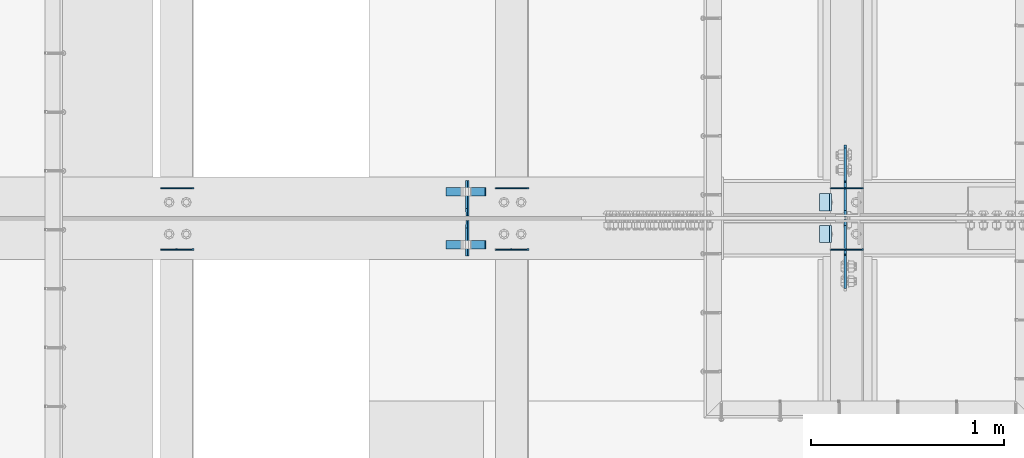
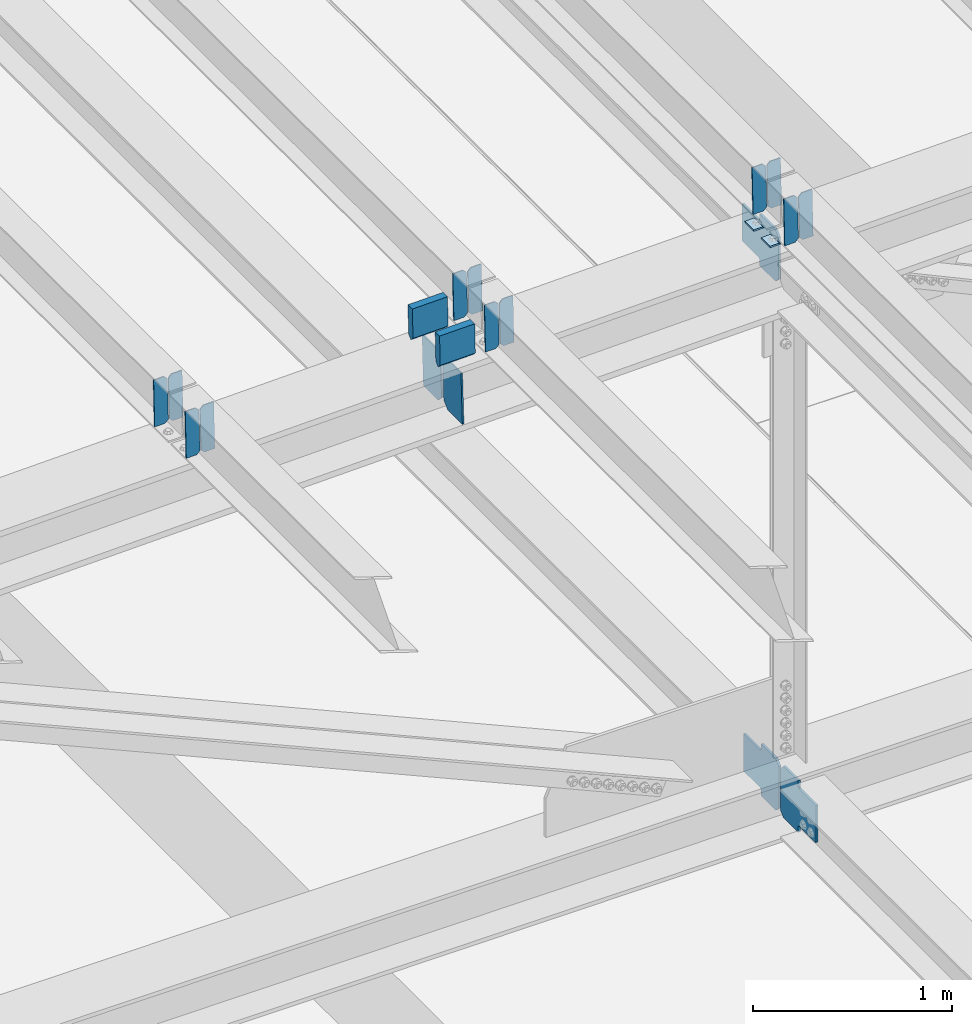
# One storey, part 3434 of 3843: 21 plates, 8 elements without a shape of their own.
"""IFC2X3 building model written with IfcOpenShell, lengths in millimetres."""

from ifc_helpers import new_model, si_unit, frame, origin_with_axes, place, context, subcontext, project, spatial, faceted_brep, material, type_object, element, aggregate, save


model = new_model("IFC2X3")

# Units and contexts
model_context = context("Model", 3, precision=1e-05, world=origin_with_axes())
body_context = subcontext(model_context, "Body", "Model", "MODEL_VIEW")
ifc_project = project(units=[si_unit("LENGTHUNIT", "METRE", prefix="MILLI"), si_unit("AREAUNIT", "SQUARE_METRE"), si_unit("VOLUMEUNIT", "CUBIC_METRE"), si_unit("MASSUNIT", "GRAM", prefix="KILO"), si_unit("TIMEUNIT", "SECOND"), si_unit("PLANEANGLEUNIT", "RADIAN"), si_unit("SOLIDANGLEUNIT", "STERADIAN"), si_unit("THERMODYNAMICTEMPERATUREUNIT", "DEGREE_CELSIUS"), si_unit("LUMINOUSINTENSITYUNIT", "LUMEN")], contexts=[model_context])

# Site, building, storey
site_placement = place(None, origin_with_axes())
site = spatial("IfcSite", under=ifc_project, at=site_placement, CompositionType="ELEMENT")
building_placement = place(site_placement, origin_with_axes())
building = spatial("IfcBuilding", under=site, at=building_placement, Name="Undefined", CompositionType="ELEMENT")
storey_placement = place(building_placement, origin_with_axes())
storey = spatial("IfcBuildingStorey", under=building, at=storey_placement, Name="Undefined", CompositionType="ELEMENT", Elevation=0.0)

# Assembly, plates
assembly_1_placement = place(storey_placement, origin_with_axes())
assembly_1 = element("IfcElementAssembly", 1, at=assembly_1_placement, inside=storey, Name="BEAM", AssemblyPlace="NOTDEFINED", PredefinedType="RIGID_FRAME")
ifc_material = material(Name="STEEL/A572-50")
plate_type_1 = type_object("IfcPlateType", PredefinedType="NOTDEFINED")
plate_1_placement = place(assembly_1_placement, frame((49078.8964783454, 67427.1449316695, 45754.9808067172), z_axis=(-0.0211520979474298, 0.0011058869996923, 0.999775657718454), x_axis=(-0.999776269348562, -2.42820000429985e-05, -0.0211520840073776)))
plate_1 = element("IfcPlate", 2, at=plate_1_placement, type_object=plate_type_1, material=ifc_material, Name="PLATE", context=body_context, shape_type="Brep", body=[
    faceted_brep([(0.0, -3.17499999999927, 0.0), (6.83940015733242e-10, -3.17499999996653, 288.924999998613), (6.54836185276508e-10, 3.17500000001746, 288.924999998591), (0.0, 3.17499999999927, 0.0), (60.3250007643655, -3.17500000017753, 288.924999998606), (60.3250007643219, 3.17499999979918, 288.924999998584), (79.3750000013097, -3.17500000025029, 269.875000761494), (79.375000001266, 3.17499999972642, 269.875000761487), (79.375000000713, -3.17500000026484, 19.0499992370605), (79.3750000006985, 3.17499999971187, 19.0499992370533), (60.325000763667, -3.17500000020664, -1.45519152283669e-11), (60.3250007636234, 3.17499999977736, -3.63797880709171e-11)], [[[0, 1, 2, 3]], [[1, 4, 5, 2]], [[4, 6, 7, 5]], [[6, 8, 9, 7]], [[8, 10, 11, 9]], [[10, 0, 3, 11]], [[5, 7, 9, 11, 3, 2]], [[10, 8, 6, 4, 1, 0]]]),
])
plate_2_placement = place(assembly_1_placement, frame((48993.1906576557, 67427.142925955, 45753.1675442254), z_axis=(-0.0211520979474298, 0.0011058869996923, 0.999775657718454), x_axis=(-0.999776269348562, -2.42820000429985e-05, -0.0211520840073776)))
plate_2 = element("IfcPlate", 3, at=plate_2_placement, type_object=plate_type_1, material=ifc_material, Name="PLATE", context=body_context, shape_type="Brep", body=[
    faceted_brep([(4.36557456851006e-11, -3.17499999998836, 19.0499992370969), (6.11180439591408e-10, -3.17499999996653, 269.875000761516), (5.96628524363041e-10, 3.17500000001746, 269.875000761502), (1.45519152283669e-11, 3.17499999998836, 19.0499992370824), (19.0499992376572, -3.17500000003201, 288.924999998606), (19.0499992376281, 3.1749999999447, 288.924999998584), (79.3750000013242, -3.17500000025029, 288.924999998591), (79.3750000013097, 3.1749999997337, 288.92499999857), (79.3750000006548, -3.17500000026484, -2.18278728425503e-11), (79.3750000006403, 3.17499999969732, -2.91038304567337e-11), (19.0499992370023, -3.17500000005384, 0.0), (19.0499992369587, 3.17499999992287, -1.45519152283669e-11)], [[[0, 1, 2, 3]], [[1, 4, 5, 2]], [[4, 6, 7, 5]], [[6, 8, 9, 7]], [[8, 10, 11, 9]], [[10, 0, 3, 11]], [[5, 7, 9, 11, 3, 2]], [[10, 8, 6, 4, 1, 0]]]),
])

assembly_2_placement = place(storey_placement, origin_with_axes())
assembly_2 = element("IfcElementAssembly", 4, at=assembly_2_placement, inside=storey, Name="BEAM", AssemblyPlace="NOTDEFINED", PredefinedType="RIGID_FRAME")
plate_3_placement = place(assembly_2_placement, frame((49078.8964783439, 67109.9214228486, 45755.1816215357), z_axis=(-0.0211520983485098, 0.000179631000035443, 0.999776253202765), x_axis=(-0.999776269342228, -3.16699999781408e-06, -0.0211520980072162)))
plate_3 = element("IfcPlate", 5, at=plate_3_placement, type_object=plate_type_1, material=ifc_material, Name="PLATE", context=body_context, shape_type="Brep", body=[
    faceted_brep([(0.0, -3.17499999999927, 0.0), (6.83940015733242e-10, -3.17499999996653, 288.924999998613), (6.54836185276508e-10, 3.17500000001746, 288.924999998591), (0.0, 3.17499999999927, 0.0), (60.3250007643655, -3.17500000017753, 288.924999998606), (60.3250007643219, 3.17499999979918, 288.924999998584), (79.3750000013097, -3.17500000025029, 269.875000761494), (79.375000001266, 3.17499999972642, 269.875000761487), (79.375000000713, -3.17500000026484, 19.0499992370605), (79.3750000006985, 3.17499999971187, 19.0499992370533), (60.325000763667, -3.17500000020664, -1.45519152283669e-11), (60.3250007636234, 3.17499999977736, -3.63797880709171e-11)], [[[0, 1, 2, 3]], [[1, 4, 5, 2]], [[4, 6, 7, 5]], [[6, 8, 9, 7]], [[8, 10, 11, 9]], [[10, 0, 3, 11]], [[5, 7, 9, 11, 3, 2]], [[10, 8, 6, 4, 1, 0]]]),
])
plate_4_placement = place(assembly_2_placement, frame((48993.1906576542, 67109.9210970575, 45753.3683579633), z_axis=(-0.0211520983485098, 0.000179631000035443, 0.999776253202765), x_axis=(-0.999776269342228, -3.16699999781408e-06, -0.0211520980072162)))
plate_4 = element("IfcPlate", 6, at=plate_4_placement, type_object=plate_type_1, material=ifc_material, Name="PLATE", context=body_context, shape_type="Brep", body=[
    faceted_brep([(4.36557456851006e-11, -3.17499999998836, 19.0499992370969), (6.11180439591408e-10, -3.17499999996653, 269.875000761516), (5.96628524363041e-10, 3.17500000001746, 269.875000761502), (1.45519152283669e-11, 3.17499999998836, 19.0499992370824), (19.0499992376572, -3.17500000003201, 288.924999998606), (19.0499992376281, 3.1749999999447, 288.924999998584), (79.3750000013242, -3.17500000025029, 288.924999998591), (79.3750000013097, 3.1749999997337, 288.92499999857), (79.3750000006548, -3.17500000026484, -2.18278728425503e-11), (79.3750000006403, 3.17499999969732, -2.91038304567337e-11), (19.0499992370023, -3.17500000005384, 0.0), (19.0499992369587, 3.17499999992287, -1.45519152283669e-11)], [[[0, 1, 2, 3]], [[1, 4, 5, 2]], [[4, 6, 7, 5]], [[6, 8, 9, 7]], [[8, 10, 11, 9]], [[10, 0, 3, 11]], [[5, 7, 9, 11, 3, 2]], [[10, 8, 6, 4, 1, 0]]]),
])

assembly_3_placement = place(storey_placement, origin_with_axes())
assembly_3 = element("IfcElementAssembly", 7, at=assembly_3_placement, inside=storey, Name="BEAM", AssemblyPlace="NOTDEFINED", PredefinedType="RIGID_FRAME")
plate_5_placement = place(assembly_3_placement, frame((45611.7964783222, 67427.2252958583, 45667.5860022229), z_axis=(-0.0211520984153467, 0.000836747000153993, 0.999775919187437), x_axis=(-0.999776269348226, -1.83429999838905e-05, -0.0211520900073297)))
plate_5 = element("IfcPlate", 8, at=plate_5_placement, type_object=plate_type_1, material=ifc_material, Name="PLATE", context=body_context, shape_type="Brep", body=[
    faceted_brep([(0.0, -3.17499999999927, 0.0), (6.83940015733242e-10, -3.17499999996653, 288.924999998613), (6.54836185276508e-10, 3.17500000001746, 288.924999998591), (0.0, 3.17499999999927, 0.0), (60.3250007643655, -3.17500000017753, 288.924999998606), (60.3250007643219, 3.17499999979918, 288.924999998584), (79.3750000013097, -3.17500000025029, 269.875000761494), (79.375000001266, 3.17499999972642, 269.875000761487), (79.375000000713, -3.17500000026484, 19.0499992370605), (79.3750000006985, 3.17499999971187, 19.0499992370533), (60.325000763667, -3.17500000020664, -1.45519152283669e-11), (60.3250007636234, 3.17499999977736, -3.63797880709171e-11)], [[[0, 1, 2, 3]], [[1, 4, 5, 2]], [[4, 6, 7, 5]], [[6, 8, 9, 7]], [[8, 10, 11, 9]], [[10, 0, 3, 11]], [[5, 7, 9, 11, 3, 2]], [[10, 8, 6, 4, 1, 0]]]),
])
plate_6_placement = place(assembly_3_placement, frame((45526.0906576326, 67427.2237782747, 45665.7727392566), z_axis=(-0.0211520984153467, 0.000836747000153993, 0.999775919187437), x_axis=(-0.999776269348226, -1.83429999838905e-05, -0.0211520900073297)))
plate_6 = element("IfcPlate", 9, at=plate_6_placement, type_object=plate_type_1, material=ifc_material, Name="PLATE", context=body_context, shape_type="Brep", body=[
    faceted_brep([(4.36557456851006e-11, -3.17499999998836, 19.0499992370969), (6.11180439591408e-10, -3.17499999996653, 269.875000761516), (5.96628524363041e-10, 3.17500000001746, 269.875000761502), (1.45519152283669e-11, 3.17499999998836, 19.0499992370824), (19.0499992376572, -3.17500000003201, 288.924999998606), (19.0499992376281, 3.1749999999447, 288.924999998584), (79.3750000013242, -3.17500000025029, 288.924999998591), (79.3750000013097, 3.1749999997337, 288.92499999857), (79.3750000006548, -3.17500000026484, -2.18278728425503e-11), (79.3750000006403, 3.17499999969732, -2.91038304567337e-11), (19.0499992370023, -3.17500000005384, 0.0), (19.0499992369587, 3.17499999992287, -1.45519152283669e-11)], [[[0, 1, 2, 3]], [[1, 4, 5, 2]], [[4, 6, 7, 5]], [[6, 8, 9, 7]], [[8, 10, 11, 9]], [[10, 0, 3, 11]], [[5, 7, 9, 11, 3, 2]], [[10, 8, 6, 4, 1, 0]]]),
])
aggregate(assembly_3, [plate_5, plate_6])

assembly_4_placement = place(storey_placement, origin_with_axes())
assembly_4 = element("IfcElementAssembly", 10, at=assembly_4_placement, inside=storey, Name="BEAM", AssemblyPlace="NOTDEFINED", PredefinedType="RIGID_FRAME")
plate_7_placement = place(assembly_4_placement, frame((45611.7964783118, 67109.9363763834, 45667.7369696016), z_axis=(-0.0211520981847716, 0.000129491999992752, 0.999776260957522), x_axis=(-0.999776269342228, -3.16699999781408e-06, -0.0211520980072162)))
plate_7 = element("IfcPlate", 11, at=plate_7_placement, type_object=plate_type_1, material=ifc_material, Name="PLATE", context=body_context, shape_type="Brep", body=[
    faceted_brep([(0.0, -3.17499999999927, 0.0), (6.83940015733242e-10, -3.17499999996653, 288.924999998613), (6.54836185276508e-10, 3.17500000001746, 288.924999998591), (0.0, 3.17499999999927, 0.0), (60.3250007643655, -3.17500000017753, 288.924999998606), (60.3250007643219, 3.17499999979918, 288.924999998584), (79.3750000013097, -3.17500000025029, 269.875000761494), (79.375000001266, 3.17499999972642, 269.875000761487), (79.375000000713, -3.17500000026484, 19.0499992370605), (79.3750000006985, 3.17499999971187, 19.0499992370533), (60.325000763667, -3.17500000020664, -1.45519152283669e-11), (60.3250007636234, 3.17499999977736, -3.63797880709171e-11)], [[[0, 1, 2, 3]], [[1, 4, 5, 2]], [[4, 6, 7, 5]], [[6, 8, 9, 7]], [[8, 10, 11, 9]], [[10, 0, 3, 11]], [[5, 7, 9, 11, 3, 2]], [[10, 8, 6, 4, 1, 0]]]),
])
plate_8_placement = place(assembly_4_placement, frame((45526.0906576224, 67109.9361415275, 45665.9237060156), z_axis=(-0.0211520981847716, 0.000129491999992752, 0.999776260957522), x_axis=(-0.999776269342228, -3.16699999781408e-06, -0.0211520980072162)))
plate_8 = element("IfcPlate", 12, at=plate_8_placement, type_object=plate_type_1, material=ifc_material, Name="PLATE", context=body_context, shape_type="Brep", body=[
    faceted_brep([(4.36557456851006e-11, -3.17499999998836, 19.0499992370969), (6.11180439591408e-10, -3.17499999996653, 269.875000761516), (5.96628524363041e-10, 3.17500000001746, 269.875000761502), (1.45519152283669e-11, 3.17499999998836, 19.0499992370824), (19.0499992376572, -3.17500000003201, 288.924999998606), (19.0499992376281, 3.1749999999447, 288.924999998584), (79.3750000013242, -3.17500000025029, 288.924999998591), (79.3750000013097, 3.1749999997337, 288.92499999857), (79.3750000006548, -3.17500000026484, -2.18278728425503e-11), (79.3750000006403, 3.17499999969732, -2.91038304567337e-11), (19.0499992370023, -3.17500000005384, 0.0), (19.0499992369587, 3.17499999992287, -1.45519152283669e-11)], [[[0, 1, 2, 3]], [[1, 4, 5, 2]], [[4, 6, 7, 5]], [[6, 8, 9, 7]], [[8, 10, 11, 9]], [[10, 0, 3, 11]], [[5, 7, 9, 11, 3, 2]], [[10, 8, 6, 4, 1, 0]]]),
])
aggregate(assembly_4, [plate_7, plate_8])

assembly_5_placement = place(storey_placement, origin_with_axes())
assembly_5 = element("IfcElementAssembly", 13, at=assembly_5_placement, inside=storey, Name="BEAM", AssemblyPlace="NOTDEFINED", PredefinedType="RIGID_FRAME")
plate_9_placement = place(assembly_5_placement, frame((47345.3466583369, 67427.1832303942, 45711.5921416276), z_axis=(-0.0211520981419525, 0.000977640000332028, 0.999775791347352), x_axis=(-0.999776269351802, -2.03449999561139e-05, -0.0211520880074371)))
plate_9 = element("IfcPlate", 14, at=plate_9_placement, type_object=plate_type_1, material=ifc_material, Name="PLATE", context=body_context, shape_type="Brep", body=[
    faceted_brep([(0.0, -3.17499999999927, 0.0), (6.83940015733242e-10, -3.17499999996653, 288.924999998613), (6.54836185276508e-10, 3.17500000001746, 288.924999998591), (0.0, 3.17499999999927, 0.0), (60.3250007643655, -3.17500000017753, 288.924999998606), (60.3250007643219, 3.17499999979918, 288.924999998584), (79.3750000013097, -3.17500000025029, 269.875000761494), (79.375000001266, 3.17499999972642, 269.875000761487), (79.375000000713, -3.17500000026484, 19.0499992370605), (79.3750000006985, 3.17499999971187, 19.0499992370533), (60.325000763667, -3.17500000020664, -1.45519152283669e-11), (60.3250007636234, 3.17499999977736, -3.63797880709171e-11)], [[[0, 1, 2, 3]], [[1, 4, 5, 2]], [[4, 6, 7, 5]], [[6, 8, 9, 7]], [[8, 10, 11, 9]], [[10, 0, 3, 11]], [[5, 7, 9, 11, 3, 2]], [[10, 8, 6, 4, 1, 0]]]),
])
plate_10_placement = place(assembly_5_placement, frame((47259.6408376472, 67427.1814553904, 45709.7788788948), z_axis=(-0.0211520981419525, 0.000977640000332028, 0.999775791347352), x_axis=(-0.999776269351802, -2.03449999561139e-05, -0.0211520880074371)))
plate_10 = element("IfcPlate", 15, at=plate_10_placement, type_object=plate_type_1, material=ifc_material, Name="PLATE", context=body_context, shape_type="Brep", body=[
    faceted_brep([(4.36557456851006e-11, -3.17499999998836, 19.0499992370969), (6.11180439591408e-10, -3.17499999996653, 269.875000761516), (5.96628524363041e-10, 3.17500000001746, 269.875000761502), (1.45519152283669e-11, 3.17499999998836, 19.0499992370824), (19.0499992376572, -3.17500000003201, 288.924999998606), (19.0499992376281, 3.1749999999447, 288.924999998584), (79.3750000013242, -3.17500000025029, 288.924999998591), (79.3750000013097, 3.1749999997337, 288.92499999857), (79.3750000006548, -3.17500000026484, -2.18278728425503e-11), (79.3750000006403, 3.17499999969732, -2.91038304567337e-11), (19.0499992370023, -3.17500000005384, 0.0), (19.0499992369587, 3.17499999992287, -1.45519152283669e-11)], [[[0, 1, 2, 3]], [[1, 4, 5, 2]], [[4, 6, 7, 5]], [[6, 8, 9, 7]], [[8, 10, 11, 9]], [[10, 0, 3, 11]], [[5, 7, 9, 11, 3, 2]], [[10, 8, 6, 4, 1, 0]]]),
])
aggregate(assembly_5, [plate_9, plate_10])

assembly_6_placement = place(storey_placement, origin_with_axes())
assembly_6 = element("IfcElementAssembly", 16, at=assembly_6_placement, inside=storey, Name="BEAM", AssemblyPlace="NOTDEFINED", PredefinedType="RIGID_FRAME")
plate_11_placement = place(assembly_6_placement, frame((47345.3466540612, 67109.9288253753, 45711.7690608367), z_axis=(-0.0211520982573566, 0.000154804000056174, 0.999776257357131), x_axis=(-0.999776269342228, -3.16699999781408e-06, -0.0211520980072162)))
plate_11 = element("IfcPlate", 17, at=plate_11_placement, type_object=plate_type_1, material=ifc_material, Name="PLATE", context=body_context, shape_type="Brep", body=[
    faceted_brep([(0.0, -3.17499999999927, 0.0), (6.83940015733242e-10, -3.17499999996653, 288.924999998613), (6.54836185276508e-10, 3.17500000001746, 288.924999998591), (0.0, 3.17499999999927, 0.0), (60.3250007643655, -3.17500000017753, 288.924999998606), (60.3250007643219, 3.17499999979918, 288.924999998584), (79.3750000013097, -3.17500000025029, 269.875000761494), (79.375000001266, 3.17499999972642, 269.875000761487), (79.375000000713, -3.17500000026484, 19.0499992370605), (79.3750000006985, 3.17499999971187, 19.0499992370533), (60.325000763667, -3.17500000020664, -1.45519152283669e-11), (60.3250007636234, 3.17499999977736, -3.63797880709171e-11)], [[[0, 1, 2, 3]], [[1, 4, 5, 2]], [[4, 6, 7, 5]], [[6, 8, 9, 7]], [[8, 10, 11, 9]], [[10, 0, 3, 11]], [[5, 7, 9, 11, 3, 2]], [[10, 8, 6, 4, 1, 0]]]),
])
plate_12_placement = place(assembly_6_placement, frame((47259.6408333719, 67109.9285464988, 45709.9557972557), z_axis=(-0.0211520982573566, 0.000154804000056174, 0.999776257357131), x_axis=(-0.999776269342228, -3.16699999781408e-06, -0.0211520980072162)))
plate_12 = element("IfcPlate", 18, at=plate_12_placement, type_object=plate_type_1, material=ifc_material, Name="PLATE", context=body_context, shape_type="Brep", body=[
    faceted_brep([(4.36557456851006e-11, -3.17499999998836, 19.0499992370969), (6.11180439591408e-10, -3.17499999996653, 269.875000761516), (5.96628524363041e-10, 3.17500000001746, 269.875000761502), (1.45519152283669e-11, 3.17499999998836, 19.0499992370824), (19.0499992376572, -3.17500000003201, 288.924999998606), (19.0499992376281, 3.1749999999447, 288.924999998584), (79.3750000013242, -3.17500000025029, 288.924999998591), (79.3750000013097, 3.1749999997337, 288.92499999857), (79.3750000006548, -3.17500000026484, -2.18278728425503e-11), (79.3750000006403, 3.17499999969732, -2.91038304567337e-11), (19.0499992370023, -3.17500000005384, 0.0), (19.0499992369587, 3.17499999992287, -1.45519152283669e-11)], [[[0, 1, 2, 3]], [[1, 4, 5, 2]], [[4, 6, 7, 5]], [[6, 8, 9, 7]], [[8, 10, 11, 9]], [[10, 0, 3, 11]], [[5, 7, 9, 11, 3, 2]], [[10, 8, 6, 4, 1, 0]]]),
])
aggregate(assembly_6, [plate_11, plate_12])

assembly_7_placement = place(storey_placement, origin_with_axes())
assembly_7 = element("IfcElementAssembly", 19, at=assembly_7_placement, inside=storey, Name="BEAM", AssemblyPlace="NOTDEFINED", PredefinedType="RIGID_FRAME")
plate_type_2 = type_object("IfcPlateType", PredefinedType="NOTDEFINED")
plate_13_placement = place(assembly_7_placement, frame((47032.8392900727, 67076.3375, 45337.6578141575), z_axis=(-0.0258271990066861, 0.0, 0.99966642225868), x_axis=(0.0, 1.0, 0.0)))
plate_13 = element("IfcPlate", 20, at=plate_13_placement, type_object=plate_type_2, material=ifc_material, Name="PL", context=body_context, shape_type="Brep", body=[
    faceted_brep([(0.0, -4.76249999999709, 0.0), (0.0, -4.76249999986612, 316.893560966142), (0.0, 4.7625000000844, 316.893560966142), (0.0, 4.76249999999709, 0.0), (145.746763610834, -4.76249999986612, 316.893560966142), (145.746763610834, 4.7625000000844, 316.893560966142), (184.149999999994, -4.76249999989523, 278.490324577106), (184.149999999994, 4.76250000006985, 278.490324577098), (184.149999999994, -4.76249999999709, 38.4032363890365), (184.149999999994, 4.76249999998254, 38.4032363890365), (145.746763610834, -4.76250000001164, 7.27595761418343e-12), (145.746763610834, 4.76249999995343, 0.0)], [[[0, 1, 2, 3]], [[1, 4, 5, 2]], [[4, 6, 7, 5]], [[6, 8, 9, 7]], [[8, 10, 11, 9]], [[10, 0, 3, 11]], [[5, 7, 9, 11, 3, 2]], [[10, 8, 6, 4, 1, 0]]]),
])
plate_14_placement = place(assembly_7_placement, frame((47032.8392900727, 67283.3125, 45337.6578141575), z_axis=(-0.0258271990066861, 0.0, 0.99966642225868), x_axis=(0.0, 1.0, 0.0)))
plate_14 = element("IfcPlate", 21, at=plate_14_placement, type_object=plate_type_2, material=ifc_material, Name="PL", context=body_context, shape_type="Brep", body=[
    faceted_brep([(0.0, -4.76249999999709, 38.4032363890365), (0.0, -4.76249999989523, 278.490324577106), (0.0, 4.76250000006985, 278.490324577098), (0.0, 4.76249999998254, 38.4032363890365), (38.4032363891602, -4.76249999986612, 316.893560966142), (38.4032363891602, 4.7625000000844, 316.893560966142), (184.149999999994, -4.76249999986612, 316.893560966142), (184.149999999994, 4.7625000000844, 316.893560966142), (184.150000000009, -4.76249999999709, 0.0), (184.150000000009, 4.76249999999709, 0.0), (38.4032363891602, -4.76250000001164, 7.27595761418343e-12), (38.4032363891602, 4.76249999995343, 0.0)], [[[0, 1, 2, 3]], [[1, 4, 5, 2]], [[4, 6, 7, 5]], [[6, 8, 9, 7]], [[8, 10, 11, 9]], [[10, 0, 3, 11]], [[5, 7, 9, 11, 3, 2]], [[10, 8, 6, 4, 1, 0]]]),
])
plate_type_3 = type_object("IfcPlateType", PredefinedType="NOTDEFINED")
plate_15_placement = place(assembly_7_placement, frame((46917.2334654147, 67408.028125, 45894.9384944989), z_axis=(0.0217666070074993, 0.0, -0.999763079343992), x_axis=(0.999763079343992, 0.0, 0.0217666070075027)))
plate_15 = element("IfcPlate", 22, at=plate_15_placement, type_object=plate_type_3, material=ifc_material, Name="PLATE", context=body_context, shape_type="Brep", body=[
    faceted_brep([(203.200005058941, -22.2250000000058, -1.16415321826935e-10), (7.27595761418343e-12, -22.2250000000058, -7.27595761418343e-12), (7.27595761418343e-12, 22.2250000000058, -7.27595761418343e-12), (203.200005058941, 22.2250000000058, -1.16415321826935e-10), (203.838531807472, -22.2250000000058, 0.00187068080413155), (203.838531807472, 22.2250000000058, 0.00187068080413155), (203.310341304641, -22.2250000000058, 180.861817383484), (0.04046799018397, -22.2250000000058, 180.907287948779), (203.245434494536, 0.0133131837355904, 203.086833080139), (0.0454396034692763, 0.0133129994646879, 203.132287829787), (0.0404679902494536, 22.2250000000058, 180.907288225317), (203.310341303353, 22.2250000000058, 180.861817822159)], [[[0, 1, 2, 3]], [[4, 0, 3, 5]], [[1, 0, 4, 6, 7]], [[7, 6, 8, 9]], [[2, 1, 7, 9, 10]], [[5, 3, 2, 10, 11]], [[6, 4, 5, 11, 8]], [[10, 9, 8, 11]]]),
])
plate_16_placement = place(assembly_7_placement, frame((46917.2334654147, 67134.978125, 45894.9384944989), z_axis=(0.0217666070074993, 0.0, -0.999763079343992), x_axis=(0.999763079343992, 0.0, 0.0217666070075027)))
plate_16 = element("IfcPlate", 23, at=plate_16_placement, type_object=plate_type_3, material=ifc_material, Name="PLATE", context=body_context, shape_type="Brep", body=[
    faceted_brep([(203.200005058941, -22.2250000000058, -1.16415321826935e-10), (7.27595761418343e-12, -22.2250000000058, -7.27595761418343e-12), (7.27595761418343e-12, 22.2250000000058, -7.27595761418343e-12), (203.200005058941, 22.2250000000058, -1.16415321826935e-10), (203.838531807472, -22.2250000000058, 0.00187068080413155), (203.838531807472, 22.2250000000058, 0.00187068080413155), (203.310341304641, -22.2250000000058, 180.861817383484), (0.04046799018397, -22.2250000000058, 180.907287948779), (203.245434494536, 0.0133131837355904, 203.086833080139), (0.0454396034692763, 0.0133129994646879, 203.132287829787), (0.0404679902494536, 22.2250000000058, 180.907288225317), (203.310341303353, 22.2250000000058, 180.861817822159)], [[[0, 1, 2, 3]], [[4, 0, 3, 5]], [[1, 0, 4, 6, 7]], [[7, 6, 8, 9]], [[2, 1, 7, 9, 10]], [[5, 3, 2, 10, 11]], [[6, 4, 5, 11, 8]], [[10, 9, 8, 11]]]),
])

# Plate
plate_type_4 = type_object("IfcPlateType", PredefinedType="NOTDEFINED")
plate_17_placement = place(assembly_1_placement, frame((48913.9677301076, 67398.8999999999, 45745.3118263068), z_axis=(0.0, -1.0, 0.0), x_axis=(-0.999776270257024, 0.0, -0.0211520550054595)))
plate_17 = element("IfcPlate", 24, at=plate_17_placement, type_object=plate_type_4, material=ifc_material, Name="PLATE", context=body_context, shape_type="Brep", body=[
    faceted_brep([(9.52499999982683, -4.7625000001135, 88.8999999999942), (0.0, 4.76249999999709, 88.9000015258789), (0.0, 4.76249999999709, 0.0), (9.52499999981956, -4.76249999999709, 0.0), (63.4999984608512, -4.76249999988795, 88.8999999999796), (63.4999984608367, -4.76249999988795, -1.45519152283669e-11), (63.4999984608221, 4.76250000013533, -1.45519152283669e-11), (63.4999984608367, 4.76250000013533, 88.8999999999796)], [[[0, 1, 2, 3]], [[4, 5, 6, 7]], [[5, 4, 0, 3]], [[6, 5, 3, 2]], [[7, 6, 2, 1]], [[4, 7, 1, 0]]]),
])

aggregate(assembly_1, [plate_1, plate_2, plate_17])

plate_18_placement = place(assembly_2_placement, frame((48913.9677301076, 67233.8000015258, 45745.3118263068), z_axis=(0.0, -1.0, 0.0), x_axis=(-0.999776270257024, 0.0, -0.0211520550054595)))
plate_18 = element("IfcPlate", 25, at=plate_18_placement, type_object=plate_type_4, material=ifc_material, Name="PLATE", context=body_context, shape_type="Brep", body=[
    faceted_brep([(9.52499999982683, -4.7625000001135, 88.8999999999942), (0.0, 4.76249999999709, 88.9000015258789), (0.0, 4.76249999999709, 0.0), (9.52499999981956, -4.76249999999709, 0.0), (63.4999984608512, -4.76249999988795, 88.8999999999796), (63.4999984608367, -4.76249999988795, -1.45519152283669e-11), (63.4999984608221, 4.76250000013533, -1.45519152283669e-11), (63.4999984608367, 4.76250000013533, 88.8999999999796)], [[[0, 1, 2, 3]], [[4, 5, 6, 7]], [[5, 4, 0, 3]], [[6, 5, 3, 2]], [[7, 6, 2, 1]], [[4, 7, 1, 0]]]),
])

aggregate(assembly_2, [plate_3, plate_4, plate_18])

# Assembly, plates
assembly_8_placement = place(storey_placement, origin_with_axes())
assembly_8 = element("IfcElementAssembly", 26, at=assembly_8_placement, inside=storey, Name="BEAM", AssemblyPlace="NOTDEFINED", PredefinedType="RIGID_FRAME")
plate_type_5 = type_object("IfcPlateType", PredefinedType="NOTDEFINED")
plate_19_placement = place(assembly_8_placement, frame((48985.4874997443, 67279.0437499975, 42180.6802613446), z_axis=(0.0, 0.707106781186548, 0.707106781186548), x_axis=(5.70000238222118e-08, 0.707106781186546, -0.707106781186546)))
plate_19 = element("IfcPlate", 27, at=plate_19_placement, type_object=plate_type_5, material=ifc_material, Name="PLATE", context=body_context, shape_type="Brep", body=[
    faceted_brep([(0.0, -6.3499999046162, 0.0), (-179.573180609259, -6.34999999999854, 179.573180609266), (-179.573180609259, 6.34999999999854, 179.573180609266), (7.27595761418343e-12, 6.3499999046162, 0.0), (-179.573180609026, -6.34999999999854, 224.474461214617), (-179.573180609026, 6.34999999999854, 224.474461214617), (-75.738969242142, -6.34999999999854, 328.308672581479), (-75.738969242142, 6.34999999999854, 328.308672581479), (-53.1421637928288, -6.34999999999854, 305.711867206905), (-53.1421637928288, 6.34999999999854, 305.711867206905), (-49.0219873246861, -6.34999999999854, 302.958853306453), (-49.0219873246861, 6.34999999999854, 302.958853306453), (-44.1619078066506, -6.34999999999854, 301.992123383869), (-44.1619078066506, 6.34999999999854, 301.992123383869), (-39.3018282885969, -6.34999999999854, 302.958853306482), (-39.3018282885969, 6.34999999999854, 302.958853306482), (-35.181651820425, -6.34999999999854, 305.711867206948), (-35.181651820425, 6.34999999999854, 305.711867206948), (81.5616778855328, -6.34999999999854, 422.455196911935), (81.5616778855328, 6.34999999999854, 422.455196911935), (243.206288064976, -6.34999999999854, 260.810586732783), (243.206288064976, 6.34999999999854, 260.810586732783), (126.462958359116, -6.34999999999854, 144.067257027898), (126.462958359116, 6.34999999999854, 144.067257027898), (123.709944458577, -6.34999999999854, 139.947080559708), (123.709944458577, 6.34999999999854, 139.947080559708), (122.743214535949, -6.34999999999854, 135.087001041655), (122.743214535949, 6.34999999999854, 135.087001041655), (123.709944458507, -6.34999999999854, 130.226921523572), (123.709944458507, 6.34999999999854, 130.226921523572), (126.462958358985, -6.34999999999854, 126.106745055411), (126.462958358985, 6.34999999999854, 126.106745055411), (148.735492004496, -6.35000000000582, 103.834211399357), (148.735492004496, 6.35000000000582, 103.834211399357), (44.9012806051323, -6.35000000000582, -1.45519152283669e-11), (44.9012806051323, 6.35000000000582, -1.45519152283669e-11)], [[[0, 1, 2, 3]], [[1, 4, 5, 2]], [[4, 6, 7, 5]], [[6, 8, 9, 7]], [[8, 10, 11, 9]], [[10, 12, 13, 11]], [[12, 14, 15, 13]], [[14, 16, 17, 15]], [[16, 18, 19, 17]], [[18, 20, 21, 19]], [[20, 22, 23, 21]], [[22, 24, 25, 23]], [[24, 26, 27, 25]], [[26, 28, 29, 27]], [[28, 30, 31, 29]], [[30, 32, 33, 31]], [[32, 34, 35, 33]], [[34, 0, 3, 35]], [[5, 7, 9, 11, 13, 15, 17, 19, 21, 23, 25, 27, 29, 31, 33, 35, 3, 2]], [[34, 32, 30, 28, 26, 24, 22, 20, 18, 16, 14, 12, 10, 8, 6, 4, 1, 0]]]),
])
plate_20_placement = place(assembly_8_placement, frame((48985.4874997898, 67264.7562499508, 42180.6802613023), z_axis=(0.0, -0.707106781186682, 0.707106781186413), x_axis=(0.0, -0.707106781186548, -0.707106781186548)))
plate_20 = element("IfcPlate", 28, at=plate_20_placement, type_object=plate_type_5, material=ifc_material, Name="PLATE", context=body_context, shape_type="Brep", body=[
    faceted_brep([(0.0, -6.3499999046162, 0.0), (-179.573180609259, -6.34999999999854, 179.573180609266), (-179.573180609259, 6.34999999999854, 179.573180609266), (7.27595761418343e-12, 6.3499999046162, 0.0), (-179.573180609026, -6.34999999999854, 224.474461214617), (-179.573180609026, 6.34999999999854, 224.474461214617), (-75.738969242142, -6.34999999999854, 328.308672581479), (-75.738969242142, 6.34999999999854, 328.308672581479), (-53.3646792252439, -6.34999999999854, 305.934382564563), (-53.3646792252439, 6.34999999999854, 305.934382564563), (-49.2445027571048, -6.34999999999854, 303.181368664096), (-49.2445027571048, 6.34999999999854, 303.181368664096), (-44.3844232390657, -6.34999999999854, 302.214638741512), (-44.3844232390657, 6.34999999999854, 302.214638741512), (-39.5243437210302, -6.34999999999854, 303.181368664096), (-39.5243437210302, 6.34999999999854, 303.181368664096), (-35.4041672528874, -6.34999999999854, 305.934382564563), (-35.4041672528874, 6.34999999999854, 305.934382564563), (81.3391624901633, -6.34999999999854, 422.677712307603), (81.3391624901633, 6.34999999999854, 422.677712307603), (242.98377266862, -6.34999999999854, 261.033102129149), (242.98377266862, 6.34999999999854, 261.033102129149), (126.240442925573, -6.34999999999854, 144.28977238611), (126.240442925573, 6.34999999999854, 144.28977238611), (123.487429025103, -6.34999999999854, 140.169595917963), (123.487429025103, 6.34999999999854, 140.169595917963), (122.520699102515, -6.34999999999854, 135.309516399924), (122.520699102515, 6.34999999999854, 135.309516399924), (123.487429025099, -6.34999999999854, 130.449436881885), (123.487429025099, 6.34999999999854, 130.449436881885), (126.240442925573, -6.34999999999854, 126.329260413753), (126.240442925573, 6.34999999999854, 126.329260413753), (148.735492004496, -6.35000000000582, 103.834211399357), (148.735492004496, 6.35000000000582, 103.834211399357), (44.9012806051323, -6.35000000000582, -1.45519152283669e-11), (44.9012806051323, 6.35000000000582, -1.45519152283669e-11)], [[[0, 1, 2, 3]], [[1, 4, 5, 2]], [[4, 6, 7, 5]], [[6, 8, 9, 7]], [[8, 10, 11, 9]], [[10, 12, 13, 11]], [[12, 14, 15, 13]], [[14, 16, 17, 15]], [[16, 18, 19, 17]], [[18, 20, 21, 19]], [[20, 22, 23, 21]], [[22, 24, 25, 23]], [[24, 26, 27, 25]], [[26, 28, 29, 27]], [[28, 30, 31, 29]], [[30, 32, 33, 31]], [[32, 34, 35, 33]], [[34, 0, 3, 35]], [[5, 7, 9, 11, 13, 15, 17, 19, 21, 23, 25, 27, 29, 31, 33, 35, 3, 2]], [[34, 32, 30, 28, 26, 24, 22, 20, 18, 16, 14, 12, 10, 8, 6, 4, 1, 0]]]),
])
aggregate(assembly_8, [plate_19, plate_20])

# Plate
plate_21_placement = place(assembly_7_placement, frame((48985.4874999459, 67283.012500005, 45418.2186250967), z_axis=(0.0, 0.707106781186548, 0.707106781186548), x_axis=(5.70000238222118e-08, 0.707106781186546, -0.707106781186546)))
plate_21 = element("IfcPlate", 29, at=plate_21_placement, type_object=plate_type_5, material=ifc_material, Name="PLATE", context=body_context, shape_type="Brep", body=[
    faceted_brep([(0.0, -6.3499999046162, 0.0), (-179.451426902579, -6.34999999999854, 179.451426902888), (-179.451426902579, 6.34999999999854, 179.451426902888), (7.27595761418343e-12, 6.3499999046162, 0.0), (-179.451426902531, -6.34999999999854, 224.352707508471), (-179.451426902531, 6.34999999999854, 224.352707508471), (-68.320757394682, -6.34999999999854, 335.483377017285), (-68.320757394682, 6.34999999999854, 335.483377017285), (-45.9429885713944, -6.34999999999854, 313.105608193975), (-45.9429885713944, 6.34999999999854, 313.105608193975), (-41.8228121032371, -6.34999999999854, 310.352594293494), (-41.8228121032371, 6.34999999999854, 310.352594293494), (-36.9627325851652, -6.34999999999854, 309.385864370939), (-36.9627325851652, 6.34999999999854, 309.385864370939), (-32.1026530670933, -6.34999999999854, 310.352594293567), (-32.1026530670933, 6.34999999999854, 310.352594293567), (-27.9824765989106, -6.34999999999854, 313.105608194091), (-27.9824765989106, 6.34999999999854, 313.105608194091), (88.760853100448, -6.34999999999854, 429.848937894436), (88.760853100448, 6.34999999999854, 429.848937894436), (250.405463279596, -6.34999999999854, 268.204327714993), (250.405463279596, 6.34999999999854, 268.204327714993), (133.662133580157, -6.34999999999854, 151.460998014547), (133.662133580157, 6.34999999999854, 151.460998014547), (130.909119679673, -6.34999999999854, 147.340821546371), (130.909119679673, 6.34999999999854, 147.340821546371), (129.942389757074, -6.34999999999854, 142.480742028318), (129.942389757074, 6.34999999999854, 142.480742028318), (130.909119679636, -6.34999999999854, 137.620662510279), (130.909119679636, 6.34999999999854, 137.620662510279), (133.662133580099, -6.34999999999854, 133.500486042147), (133.662133580099, 6.34999999999854, 133.500486042147), (156.031950102829, -6.35000000000582, 111.130669497703), (156.031950102829, 6.35000000000582, 111.130669497703), (44.9012806051323, -6.35000000000582, -1.45519152283669e-11), (44.9012806051323, 6.35000000000582, -1.45519152283669e-11)], [[[0, 1, 2, 3]], [[1, 4, 5, 2]], [[4, 6, 7, 5]], [[6, 8, 9, 7]], [[8, 10, 11, 9]], [[10, 12, 13, 11]], [[12, 14, 15, 13]], [[14, 16, 17, 15]], [[16, 18, 19, 17]], [[18, 20, 21, 19]], [[20, 22, 23, 21]], [[22, 24, 25, 23]], [[24, 26, 27, 25]], [[26, 28, 29, 27]], [[28, 30, 31, 29]], [[30, 32, 33, 31]], [[32, 34, 35, 33]], [[34, 0, 3, 35]], [[5, 7, 9, 11, 13, 15, 17, 19, 21, 23, 25, 27, 29, 31, 33, 35, 3, 2]], [[34, 32, 30, 28, 26, 24, 22, 20, 18, 16, 14, 12, 10, 8, 6, 4, 1, 0]]]),
])

aggregate(assembly_7, [plate_15, plate_16, plate_13, plate_14, plate_21])

save(model, "model.ifc")
